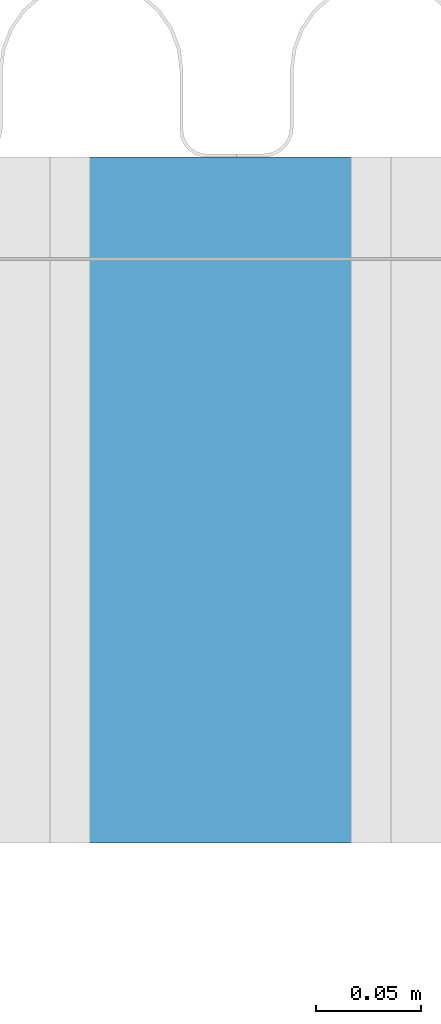
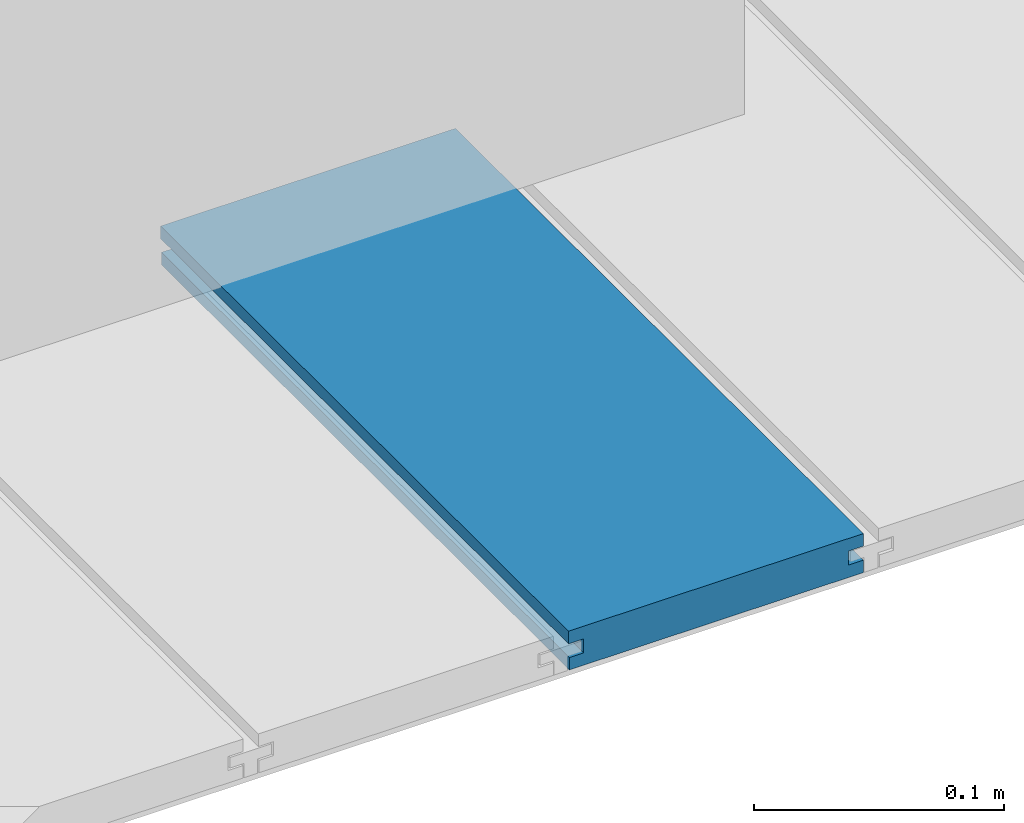
# One storey, part 21 of 33: 1 wall.
"""IFC4 building model written with IfcOpenShell, lengths in feet."""

from ifc_helpers import new_model, entity, si_unit, converted_unit, derived_unit, direction, frame, origin, place, context, subcontext, project, spatial, material, type_object, element, save


model = new_model("IFC4")

# Units and contexts
model_context = context("Model", 3, precision=0.0001, world=origin(), true_north=direction((6.12303176911189e-17, 1.0)))
body_context = subcontext(model_context, "Body", "Model", "MODEL_VIEW")
ifc_project = project(units=[converted_unit("LENGTHUNIT", "FOOT", entity("IfcRatioMeasure", 0.3048), si_unit("LENGTHUNIT", "METRE"), dimensions=[1, 0, 0, 0, 0, 0, 0]), converted_unit("AREAUNIT", "SQUARE FOOT", entity("IfcRatioMeasure", 0.09290304), si_unit("AREAUNIT", "SQUARE_METRE"), dimensions=[2, 0, 0, 0, 0, 0, 0]), converted_unit("VOLUMEUNIT", "CUBIC FOOT", entity("IfcRatioMeasure", 0.028316846592), si_unit("VOLUMEUNIT", "CUBIC_METRE"), dimensions=[3, 0, 0, 0, 0, 0, 0]), converted_unit("PLANEANGLEUNIT", "DEGREE", entity("IfcRatioMeasure", 0.0174532925199433), si_unit("PLANEANGLEUNIT", "RADIAN"), dimensions=[0, 0, 0, 0, 0, 0, 0]), si_unit("MASSUNIT", "GRAM", prefix="KILO"), derived_unit("MASSDENSITYUNIT", [(si_unit("MASSUNIT", "GRAM", prefix="KILO"), 1), (si_unit("LENGTHUNIT", "METRE"), -3)]), derived_unit("MOMENTOFINERTIAUNIT", [(si_unit("LENGTHUNIT", "METRE"), 4)]), si_unit("TIMEUNIT", "SECOND"), si_unit("FREQUENCYUNIT", "HERTZ"), si_unit("THERMODYNAMICTEMPERATUREUNIT", "DEGREE_CELSIUS"), derived_unit("THERMALTRANSMITTANCEUNIT", [(si_unit("MASSUNIT", "GRAM", prefix="KILO"), 1), (si_unit("THERMODYNAMICTEMPERATUREUNIT", "KELVIN"), -1), (si_unit("TIMEUNIT", "SECOND"), -3)]), derived_unit("VOLUMETRICFLOWRATEUNIT", [(si_unit("LENGTHUNIT", "METRE"), 3), (si_unit("TIMEUNIT", "SECOND"), -1)]), si_unit("ELECTRICCURRENTUNIT", "AMPERE"), si_unit("ELECTRICVOLTAGEUNIT", "VOLT"), si_unit("POWERUNIT", "WATT"), si_unit("FORCEUNIT", "NEWTON"), si_unit("ILLUMINANCEUNIT", "LUX"), si_unit("LUMINOUSFLUXUNIT", "LUMEN"), si_unit("LUMINOUSINTENSITYUNIT", "CANDELA"), derived_unit("USERDEFINED", [(si_unit("MASSUNIT", "GRAM", prefix="KILO"), -1), (si_unit("LENGTHUNIT", "METRE"), -2), (si_unit("TIMEUNIT", "SECOND"), 3), (si_unit("LUMINOUSFLUXUNIT", "LUMEN"), 1)]), derived_unit("LINEARVELOCITYUNIT", [(si_unit("LENGTHUNIT", "METRE"), 1), (si_unit("TIMEUNIT", "SECOND"), -1)]), si_unit("PRESSUREUNIT", "PASCAL"), derived_unit("USERDEFINED", [(si_unit("LENGTHUNIT", "METRE"), -2), (si_unit("MASSUNIT", "GRAM", prefix="KILO"), 1), (si_unit("TIMEUNIT", "SECOND"), -2)]), derived_unit("LINEARFORCEUNIT", [(si_unit("MASSUNIT", "GRAM", prefix="KILO"), 1), (si_unit("LENGTHUNIT", "METRE"), 1), (si_unit("TIMEUNIT", "SECOND"), -2), (si_unit("LENGTHUNIT", "METRE"), -1)]), derived_unit("PLANARFORCEUNIT", [(si_unit("MASSUNIT", "GRAM", prefix="KILO"), 1), (si_unit("LENGTHUNIT", "METRE"), 1), (si_unit("TIMEUNIT", "SECOND"), -2), (si_unit("LENGTHUNIT", "METRE"), -2)])], contexts=[model_context])

# Site, building, storey
site_placement = place(None, origin())
site = spatial("IfcSite", under=ifc_project, at=site_placement, CompositionType="ELEMENT")
building_placement = place(site_placement, origin())
building = spatial("IfcBuilding", under=site, at=building_placement, CompositionType="ELEMENT")
storey_placement = place(building_placement, frame((0.0, 0.0, 10.0)))
storey = spatial("IfcBuildingStorey", under=building, at=storey_placement, Name="2ND FLOOR", CompositionType="ELEMENT", Elevation=10.0000000000002)

# Wall
ifc_material = material(Name="COMPOSITE DECKING W/ HIDDEN FASTENERS", Category="Materials")
wall_type = type_object("IfcWallType", Name="Generic Models 687:Generic Models 1", PredefinedType="NOTDEFINED", material=ifc_material)
wall_placement = place(storey_placement, frame((1491.06165654238, 3.0461139299927, 0.682902157150137), z_axis=(0.0, 0.0, 1.0), x_axis=(0.0, 1.0, 0.0)))
cartesian_point_1 = entity("IfcCartesianPoint", [1.07004500651838, -0.446740923891412, 0.0])
vertex_point_1 = entity("IfcVertexPoint", cartesian_point_1)
cartesian_point_2 = entity("IfcCartesianPoint", [1.07004500651839, -0.00132475379450625, 0.0])
vertex_point_2 = entity("IfcVertexPoint", cartesian_point_2)
ifc_direction_1 = entity("IfcDirection", [0.0, 1.0, 0.0])
edge_curve_1 = entity("IfcEdgeCurve", vertex_point_1, vertex_point_2, entity("IfcTrimmedCurve", entity("IfcLine", cartesian_point_1, entity("IfcVector", ifc_direction_1, 1.0)), [cartesian_point_1], [cartesian_point_2], True, "CARTESIAN"), True)
cartesian_point_3 = entity("IfcCartesianPoint", [1.07004500651839, -0.00132475379450625, 0.0198779960861479])
vertex_point_3 = entity("IfcVertexPoint", cartesian_point_3)
ifc_direction_2 = entity("IfcDirection", [0.0, 0.0, 1.0])
edge_curve_2 = entity("IfcEdgeCurve", vertex_point_2, vertex_point_3, entity("IfcTrimmedCurve", entity("IfcLine", cartesian_point_2, entity("IfcVector", ifc_direction_2, 1.0)), [cartesian_point_2], [cartesian_point_3], True, "CARTESIAN"), True)
cartesian_point_4 = entity("IfcCartesianPoint", [1.07004500651839, -0.0228400010807945, 0.0198779960861479])
vertex_point_4 = entity("IfcVertexPoint", cartesian_point_4)
ifc_direction_3 = entity("IfcDirection", [0.0, -1.0, 0.0])
edge_curve_3 = entity("IfcEdgeCurve", vertex_point_3, vertex_point_4, entity("IfcTrimmedCurve", entity("IfcLine", cartesian_point_3, entity("IfcVector", ifc_direction_3, 1.0)), [cartesian_point_3], [cartesian_point_4], True, "CARTESIAN"), True)
cartesian_point_5 = entity("IfcCartesianPoint", [1.07004500651839, -0.0228400010807945, 0.0422987663426522])
vertex_point_5 = entity("IfcVertexPoint", cartesian_point_5)
edge_curve_4 = entity("IfcEdgeCurve", vertex_point_4, vertex_point_5, entity("IfcTrimmedCurve", entity("IfcLine", cartesian_point_4, entity("IfcVector", ifc_direction_2, 1.0)), [cartesian_point_4], [cartesian_point_5], True, "CARTESIAN"), True)
cartesian_point_6 = entity("IfcCartesianPoint", [1.07004500651839, 0.0, 0.0422987663426522])
vertex_point_6 = entity("IfcVertexPoint", cartesian_point_6)
edge_curve_5 = entity("IfcEdgeCurve", vertex_point_5, vertex_point_6, entity("IfcTrimmedCurve", entity("IfcLine", cartesian_point_5, entity("IfcVector", ifc_direction_1, 1.0)), [cartesian_point_5], [cartesian_point_6], True, "CARTESIAN"), True)
cartesian_point_7 = entity("IfcCartesianPoint", [1.07004500651839, 0.0, 0.0625000000000551])
vertex_point_7 = entity("IfcVertexPoint", cartesian_point_7)
edge_curve_6 = entity("IfcEdgeCurve", vertex_point_6, vertex_point_7, entity("IfcTrimmedCurve", entity("IfcLine", cartesian_point_6, entity("IfcVector", ifc_direction_2, 1.0)), [cartesian_point_6], [cartesian_point_7], True, "CARTESIAN"), True)
cartesian_point_8 = entity("IfcCartesianPoint", [1.07004500651838, -0.446740923891639, 0.0625])
vertex_point_8 = entity("IfcVertexPoint", cartesian_point_8)
edge_curve_7 = entity("IfcEdgeCurve", vertex_point_7, vertex_point_8, entity("IfcTrimmedCurve", entity("IfcLine", cartesian_point_7, entity("IfcVector", ifc_direction_3, 1.0)), [cartesian_point_7], [cartesian_point_8], True, "CARTESIAN"), True)
cartesian_point_9 = entity("IfcCartesianPoint", [1.07004500651838, -0.446740923891639, 0.0422987663426522])
vertex_point_9 = entity("IfcVertexPoint", cartesian_point_9)
ifc_direction_4 = entity("IfcDirection", [0.0, 0.0, -1.0])
edge_curve_8 = entity("IfcEdgeCurve", vertex_point_8, vertex_point_9, entity("IfcTrimmedCurve", entity("IfcLine", cartesian_point_8, entity("IfcVector", ifc_direction_4, 1.0)), [cartesian_point_8], [cartesian_point_9], True, "CARTESIAN"), True)
cartesian_point_10 = entity("IfcCartesianPoint", [1.07004500651838, -0.423900922810617, 0.0422987663426522])
vertex_point_10 = entity("IfcVertexPoint", cartesian_point_10)
edge_curve_9 = entity("IfcEdgeCurve", vertex_point_9, vertex_point_10, entity("IfcTrimmedCurve", entity("IfcLine", cartesian_point_9, entity("IfcVector", ifc_direction_1, 1.0)), [cartesian_point_9], [cartesian_point_10], True, "CARTESIAN"), True)
cartesian_point_11 = entity("IfcCartesianPoint", [1.07004500651838, -0.423900922810617, 0.0198779960861479])
vertex_point_11 = entity("IfcVertexPoint", cartesian_point_11)
edge_curve_10 = entity("IfcEdgeCurve", vertex_point_10, vertex_point_11, entity("IfcTrimmedCurve", entity("IfcLine", cartesian_point_10, entity("IfcVector", ifc_direction_4, 1.0)), [cartesian_point_10], [cartesian_point_11], True, "CARTESIAN"), True)
cartesian_point_12 = entity("IfcCartesianPoint", [1.07004500651838, -0.446740923891412, 0.0198779960861479])
vertex_point_12 = entity("IfcVertexPoint", cartesian_point_12)
edge_curve_11 = entity("IfcEdgeCurve", vertex_point_11, vertex_point_12, entity("IfcTrimmedCurve", entity("IfcLine", cartesian_point_11, entity("IfcVector", ifc_direction_3, 1.0)), [cartesian_point_11], [cartesian_point_12], True, "CARTESIAN"), True)
edge_curve_12 = entity("IfcEdgeCurve", vertex_point_12, vertex_point_1, entity("IfcTrimmedCurve", entity("IfcLine", cartesian_point_12, entity("IfcVector", ifc_direction_4, 1.0)), [cartesian_point_12], [cartesian_point_1], True, "CARTESIAN"), True)
ifc_direction_5 = entity("IfcDirection", [1.0, 0.0, 0.0])
cartesian_point_13 = entity("IfcCartesianPoint", [0.0, -0.446740923891412, 0.0])
vertex_point_13 = entity("IfcVertexPoint", cartesian_point_13)
cartesian_point_14 = entity("IfcCartesianPoint", [0.0, -0.446740923891412, 0.0198779960861479])
vertex_point_14 = entity("IfcVertexPoint", cartesian_point_14)
edge_curve_13 = entity("IfcEdgeCurve", vertex_point_13, vertex_point_14, entity("IfcTrimmedCurve", entity("IfcLine", cartesian_point_13, entity("IfcVector", ifc_direction_2, 1.0)), [cartesian_point_13], [cartesian_point_14], True, "CARTESIAN"), True)
cartesian_point_15 = entity("IfcCartesianPoint", [0.0, -0.423900922810617, 0.0198779960861479])
vertex_point_15 = entity("IfcVertexPoint", cartesian_point_15)
edge_curve_14 = entity("IfcEdgeCurve", vertex_point_14, vertex_point_15, entity("IfcTrimmedCurve", entity("IfcLine", cartesian_point_14, entity("IfcVector", ifc_direction_1, 1.0)), [cartesian_point_14], [cartesian_point_15], True, "CARTESIAN"), True)
cartesian_point_16 = entity("IfcCartesianPoint", [0.0, -0.423900922810617, 0.0422987663426522])
vertex_point_16 = entity("IfcVertexPoint", cartesian_point_16)
edge_curve_15 = entity("IfcEdgeCurve", vertex_point_15, vertex_point_16, entity("IfcTrimmedCurve", entity("IfcLine", cartesian_point_15, entity("IfcVector", ifc_direction_2, 1.0)), [cartesian_point_15], [cartesian_point_16], True, "CARTESIAN"), True)
cartesian_point_17 = entity("IfcCartesianPoint", [0.0, -0.446740923891639, 0.0422987663426522])
vertex_point_17 = entity("IfcVertexPoint", cartesian_point_17)
edge_curve_16 = entity("IfcEdgeCurve", vertex_point_16, vertex_point_17, entity("IfcTrimmedCurve", entity("IfcLine", cartesian_point_16, entity("IfcVector", ifc_direction_3, 1.0)), [cartesian_point_16], [cartesian_point_17], True, "CARTESIAN"), True)
cartesian_point_18 = entity("IfcCartesianPoint", [0.0, -0.446740923891639, 0.0625])
vertex_point_18 = entity("IfcVertexPoint", cartesian_point_18)
edge_curve_17 = entity("IfcEdgeCurve", vertex_point_17, vertex_point_18, entity("IfcTrimmedCurve", entity("IfcLine", cartesian_point_17, entity("IfcVector", ifc_direction_2, 1.0)), [cartesian_point_17], [cartesian_point_18], True, "CARTESIAN"), True)
cartesian_point_19 = entity("IfcCartesianPoint", [0.0, 0.0, 0.0625000000000551])
vertex_point_19 = entity("IfcVertexPoint", cartesian_point_19)
edge_curve_18 = entity("IfcEdgeCurve", vertex_point_18, vertex_point_19, entity("IfcTrimmedCurve", entity("IfcLine", cartesian_point_18, entity("IfcVector", ifc_direction_1, 1.0)), [cartesian_point_18], [cartesian_point_19], True, "CARTESIAN"), True)
cartesian_point_20 = entity("IfcCartesianPoint", [0.0, 0.0, 0.0422987663426522])
vertex_point_20 = entity("IfcVertexPoint", cartesian_point_20)
edge_curve_19 = entity("IfcEdgeCurve", vertex_point_19, vertex_point_20, entity("IfcTrimmedCurve", entity("IfcLine", cartesian_point_19, entity("IfcVector", ifc_direction_4, 1.0)), [cartesian_point_19], [cartesian_point_20], True, "CARTESIAN"), True)
cartesian_point_21 = entity("IfcCartesianPoint", [0.0, -0.0228400010807945, 0.0422987663426522])
vertex_point_21 = entity("IfcVertexPoint", cartesian_point_21)
edge_curve_20 = entity("IfcEdgeCurve", vertex_point_20, vertex_point_21, entity("IfcTrimmedCurve", entity("IfcLine", cartesian_point_20, entity("IfcVector", ifc_direction_3, 1.0)), [cartesian_point_20], [cartesian_point_21], True, "CARTESIAN"), True)
cartesian_point_22 = entity("IfcCartesianPoint", [0.0, -0.0228400010807945, 0.0198779960861479])
vertex_point_22 = entity("IfcVertexPoint", cartesian_point_22)
edge_curve_21 = entity("IfcEdgeCurve", vertex_point_21, vertex_point_22, entity("IfcTrimmedCurve", entity("IfcLine", cartesian_point_21, entity("IfcVector", ifc_direction_4, 1.0)), [cartesian_point_21], [cartesian_point_22], True, "CARTESIAN"), True)
cartesian_point_23 = entity("IfcCartesianPoint", [0.0, -0.00132475379450625, 0.0198779960861479])
vertex_point_23 = entity("IfcVertexPoint", cartesian_point_23)
edge_curve_22 = entity("IfcEdgeCurve", vertex_point_22, vertex_point_23, entity("IfcTrimmedCurve", entity("IfcLine", cartesian_point_22, entity("IfcVector", ifc_direction_1, 1.0)), [cartesian_point_22], [cartesian_point_23], True, "CARTESIAN"), True)
cartesian_point_24 = entity("IfcCartesianPoint", [0.0, -0.00132475379450625, 0.0])
vertex_point_24 = entity("IfcVertexPoint", cartesian_point_24)
edge_curve_23 = entity("IfcEdgeCurve", vertex_point_23, vertex_point_24, entity("IfcTrimmedCurve", entity("IfcLine", cartesian_point_23, entity("IfcVector", ifc_direction_4, 1.0)), [cartesian_point_23], [cartesian_point_24], True, "CARTESIAN"), True)
edge_curve_24 = entity("IfcEdgeCurve", vertex_point_24, vertex_point_13, entity("IfcTrimmedCurve", entity("IfcLine", cartesian_point_24, entity("IfcVector", ifc_direction_3, 1.0)), [cartesian_point_24], [cartesian_point_13], True, "CARTESIAN"), True)
ifc_direction_6 = entity("IfcDirection", [-1.0, 0.0, 0.0])
edge_curve_25 = entity("IfcEdgeCurve", vertex_point_13, vertex_point_1, entity("IfcTrimmedCurve", entity("IfcLine", cartesian_point_13, entity("IfcVector", ifc_direction_5, 1.0)), [cartesian_point_13], [cartesian_point_1], True, "CARTESIAN"), True)
edge_curve_26 = entity("IfcEdgeCurve", vertex_point_12, vertex_point_14, entity("IfcTrimmedCurve", entity("IfcLine", cartesian_point_14, entity("IfcVector", ifc_direction_6, 1.0)), [cartesian_point_12], [cartesian_point_14], True, "CARTESIAN"), True)
edge_curve_27 = entity("IfcEdgeCurve", vertex_point_18, vertex_point_8, entity("IfcTrimmedCurve", entity("IfcLine", cartesian_point_18, entity("IfcVector", ifc_direction_5, 1.0)), [cartesian_point_18], [cartesian_point_8], True, "CARTESIAN"), True)
edge_curve_28 = entity("IfcEdgeCurve", vertex_point_7, vertex_point_19, entity("IfcTrimmedCurve", entity("IfcLine", cartesian_point_19, entity("IfcVector", ifc_direction_6, 1.0)), [cartesian_point_7], [cartesian_point_19], True, "CARTESIAN"), True)
edge_curve_29 = entity("IfcEdgeCurve", vertex_point_6, vertex_point_20, entity("IfcTrimmedCurve", entity("IfcLine", cartesian_point_20, entity("IfcVector", ifc_direction_6, 1.0)), [cartesian_point_6], [cartesian_point_20], True, "CARTESIAN"), True)
edge_curve_30 = entity("IfcEdgeCurve", vertex_point_24, vertex_point_2, entity("IfcTrimmedCurve", entity("IfcLine", cartesian_point_24, entity("IfcVector", ifc_direction_5, 1.0)), [cartesian_point_24], [cartesian_point_2], True, "CARTESIAN"), True)
edge_curve_31 = entity("IfcEdgeCurve", vertex_point_17, vertex_point_9, entity("IfcTrimmedCurve", entity("IfcLine", cartesian_point_17, entity("IfcVector", ifc_direction_5, 1.0)), [cartesian_point_17], [cartesian_point_9], True, "CARTESIAN"), True)
edge_curve_32 = entity("IfcEdgeCurve", vertex_point_5, vertex_point_21, entity("IfcTrimmedCurve", entity("IfcLine", cartesian_point_21, entity("IfcVector", ifc_direction_6, 1.0)), [cartesian_point_5], [cartesian_point_21], True, "CARTESIAN"), True)
edge_curve_33 = entity("IfcEdgeCurve", vertex_point_4, vertex_point_22, entity("IfcTrimmedCurve", entity("IfcLine", cartesian_point_22, entity("IfcVector", ifc_direction_6, 1.0)), [cartesian_point_4], [cartesian_point_22], True, "CARTESIAN"), True)
edge_curve_34 = entity("IfcEdgeCurve", vertex_point_3, vertex_point_23, entity("IfcTrimmedCurve", entity("IfcLine", cartesian_point_23, entity("IfcVector", ifc_direction_6, 1.0)), [cartesian_point_3], [cartesian_point_23], True, "CARTESIAN"), True)
edge_curve_35 = entity("IfcEdgeCurve", vertex_point_11, vertex_point_15, entity("IfcTrimmedCurve", entity("IfcLine", cartesian_point_15, entity("IfcVector", ifc_direction_6, 1.0)), [cartesian_point_11], [cartesian_point_15], True, "CARTESIAN"), True)
edge_curve_36 = entity("IfcEdgeCurve", vertex_point_10, vertex_point_16, entity("IfcTrimmedCurve", entity("IfcLine", cartesian_point_16, entity("IfcVector", ifc_direction_6, 1.0)), [cartesian_point_10], [cartesian_point_16], True, "CARTESIAN"), True)
element("IfcWall", 1, at=wall_placement, inside=storey, type_object=wall_type, material=ifc_material, Name="Generic Models 687:Generic Models 1", ObjectType="Generic Models 687:Generic Models 1", PredefinedType="NOTDEFINED", context=body_context, shape_type="AdvancedBrep", body=[
    entity("IfcAdvancedBrep", entity("IfcClosedShell", [entity("IfcAdvancedFace", [entity("IfcFaceOuterBound", entity("IfcEdgeLoop", [entity("IfcOrientedEdge", None, None, edge_curve_1, True), entity("IfcOrientedEdge", None, None, edge_curve_2, True), entity("IfcOrientedEdge", None, None, edge_curve_3, True), entity("IfcOrientedEdge", None, None, edge_curve_4, True), entity("IfcOrientedEdge", None, None, edge_curve_5, True), entity("IfcOrientedEdge", None, None, edge_curve_6, True), entity("IfcOrientedEdge", None, None, edge_curve_7, True), entity("IfcOrientedEdge", None, None, edge_curve_8, True), entity("IfcOrientedEdge", None, None, edge_curve_9, True), entity("IfcOrientedEdge", None, None, edge_curve_10, True), entity("IfcOrientedEdge", None, None, edge_curve_11, True), entity("IfcOrientedEdge", None, None, edge_curve_12, True)]), True)], entity("IfcPlane", entity("IfcAxis2Placement3D", entity("IfcCartesianPoint", [1.07004500651838, -0.446740923891412, -0.0208333333328241]), ifc_direction_5, ifc_direction_4)), True), entity("IfcAdvancedFace", [entity("IfcFaceOuterBound", entity("IfcEdgeLoop", [entity("IfcOrientedEdge", None, None, edge_curve_13, True), entity("IfcOrientedEdge", None, None, edge_curve_14, True), entity("IfcOrientedEdge", None, None, edge_curve_15, True), entity("IfcOrientedEdge", None, None, edge_curve_16, True), entity("IfcOrientedEdge", None, None, edge_curve_17, True), entity("IfcOrientedEdge", None, None, edge_curve_18, True), entity("IfcOrientedEdge", None, None, edge_curve_19, True), entity("IfcOrientedEdge", None, None, edge_curve_20, True), entity("IfcOrientedEdge", None, None, edge_curve_21, True), entity("IfcOrientedEdge", None, None, edge_curve_22, True), entity("IfcOrientedEdge", None, None, edge_curve_23, True), entity("IfcOrientedEdge", None, None, edge_curve_24, True)]), True)], entity("IfcPlane", entity("IfcAxis2Placement3D", entity("IfcCartesianPoint", [0.0, -0.446740923891412, -0.0208333333328241]), ifc_direction_6, ifc_direction_2)), True), entity("IfcAdvancedFace", [entity("IfcFaceOuterBound", entity("IfcEdgeLoop", [entity("IfcOrientedEdge", None, None, edge_curve_13, False), entity("IfcOrientedEdge", None, None, edge_curve_25, True), entity("IfcOrientedEdge", None, None, edge_curve_12, False), entity("IfcOrientedEdge", None, None, edge_curve_26, True)]), True)], entity("IfcPlane", entity("IfcAxis2Placement3D", cartesian_point_13, ifc_direction_3, ifc_direction_5)), True), entity("IfcAdvancedFace", [entity("IfcFaceOuterBound", entity("IfcEdgeLoop", [entity("IfcOrientedEdge", None, None, edge_curve_18, False), entity("IfcOrientedEdge", None, None, edge_curve_27, True), entity("IfcOrientedEdge", None, None, edge_curve_7, False), entity("IfcOrientedEdge", None, None, edge_curve_28, True)]), True)], entity("IfcPlane", entity("IfcAxis2Placement3D", cartesian_point_18, ifc_direction_2, ifc_direction_5)), True), entity("IfcAdvancedFace", [entity("IfcFaceOuterBound", entity("IfcEdgeLoop", [entity("IfcOrientedEdge", None, None, edge_curve_19, False), entity("IfcOrientedEdge", None, None, edge_curve_28, False), entity("IfcOrientedEdge", None, None, edge_curve_6, False), entity("IfcOrientedEdge", None, None, edge_curve_29, True)]), True)], entity("IfcPlane", entity("IfcAxis2Placement3D", cartesian_point_19, ifc_direction_1, ifc_direction_5)), True), entity("IfcAdvancedFace", [entity("IfcFaceOuterBound", entity("IfcEdgeLoop", [entity("IfcOrientedEdge", None, None, edge_curve_24, False), entity("IfcOrientedEdge", None, None, edge_curve_30, True), entity("IfcOrientedEdge", None, None, edge_curve_1, False), entity("IfcOrientedEdge", None, None, edge_curve_25, False)]), True)], entity("IfcPlane", entity("IfcAxis2Placement3D", cartesian_point_24, ifc_direction_4, ifc_direction_5)), True), entity("IfcAdvancedFace", [entity("IfcFaceOuterBound", entity("IfcEdgeLoop", [entity("IfcOrientedEdge", None, None, edge_curve_17, False), entity("IfcOrientedEdge", None, None, edge_curve_31, True), entity("IfcOrientedEdge", None, None, edge_curve_8, False), entity("IfcOrientedEdge", None, None, edge_curve_27, False)]), True)], entity("IfcPlane", entity("IfcAxis2Placement3D", cartesian_point_17, ifc_direction_3, ifc_direction_5)), True), entity("IfcAdvancedFace", [entity("IfcFaceOuterBound", entity("IfcEdgeLoop", [entity("IfcOrientedEdge", None, None, edge_curve_20, False), entity("IfcOrientedEdge", None, None, edge_curve_29, False), entity("IfcOrientedEdge", None, None, edge_curve_5, False), entity("IfcOrientedEdge", None, None, edge_curve_32, True)]), True)], entity("IfcPlane", entity("IfcAxis2Placement3D", cartesian_point_20, ifc_direction_4, ifc_direction_5)), True), entity("IfcAdvancedFace", [entity("IfcFaceOuterBound", entity("IfcEdgeLoop", [entity("IfcOrientedEdge", None, None, edge_curve_21, False), entity("IfcOrientedEdge", None, None, edge_curve_32, False), entity("IfcOrientedEdge", None, None, edge_curve_4, False), entity("IfcOrientedEdge", None, None, edge_curve_33, True)]), True)], entity("IfcPlane", entity("IfcAxis2Placement3D", cartesian_point_21, ifc_direction_1, ifc_direction_5)), True), entity("IfcAdvancedFace", [entity("IfcFaceOuterBound", entity("IfcEdgeLoop", [entity("IfcOrientedEdge", None, None, edge_curve_22, False), entity("IfcOrientedEdge", None, None, edge_curve_33, False), entity("IfcOrientedEdge", None, None, edge_curve_3, False), entity("IfcOrientedEdge", None, None, edge_curve_34, True)]), True)], entity("IfcPlane", entity("IfcAxis2Placement3D", cartesian_point_22, ifc_direction_2, ifc_direction_5)), True), entity("IfcAdvancedFace", [entity("IfcFaceOuterBound", entity("IfcEdgeLoop", [entity("IfcOrientedEdge", None, None, edge_curve_23, False), entity("IfcOrientedEdge", None, None, edge_curve_34, False), entity("IfcOrientedEdge", None, None, edge_curve_2, False), entity("IfcOrientedEdge", None, None, edge_curve_30, False)]), True)], entity("IfcPlane", entity("IfcAxis2Placement3D", cartesian_point_23, ifc_direction_1, ifc_direction_5)), True), entity("IfcAdvancedFace", [entity("IfcFaceOuterBound", entity("IfcEdgeLoop", [entity("IfcOrientedEdge", None, None, edge_curve_14, False), entity("IfcOrientedEdge", None, None, edge_curve_26, False), entity("IfcOrientedEdge", None, None, edge_curve_11, False), entity("IfcOrientedEdge", None, None, edge_curve_35, True)]), True)], entity("IfcPlane", entity("IfcAxis2Placement3D", cartesian_point_14, ifc_direction_2, ifc_direction_5)), True), entity("IfcAdvancedFace", [entity("IfcFaceOuterBound", entity("IfcEdgeLoop", [entity("IfcOrientedEdge", None, None, edge_curve_15, False), entity("IfcOrientedEdge", None, None, edge_curve_35, False), entity("IfcOrientedEdge", None, None, edge_curve_10, False), entity("IfcOrientedEdge", None, None, edge_curve_36, True)]), True)], entity("IfcPlane", entity("IfcAxis2Placement3D", cartesian_point_15, ifc_direction_3, ifc_direction_5)), True), entity("IfcAdvancedFace", [entity("IfcFaceOuterBound", entity("IfcEdgeLoop", [entity("IfcOrientedEdge", None, None, edge_curve_16, False), entity("IfcOrientedEdge", None, None, edge_curve_36, False), entity("IfcOrientedEdge", None, None, edge_curve_9, False), entity("IfcOrientedEdge", None, None, edge_curve_31, False)]), True)], entity("IfcPlane", entity("IfcAxis2Placement3D", cartesian_point_16, ifc_direction_4, ifc_direction_5)), True)])),
])

save(model, "model.ifc")
